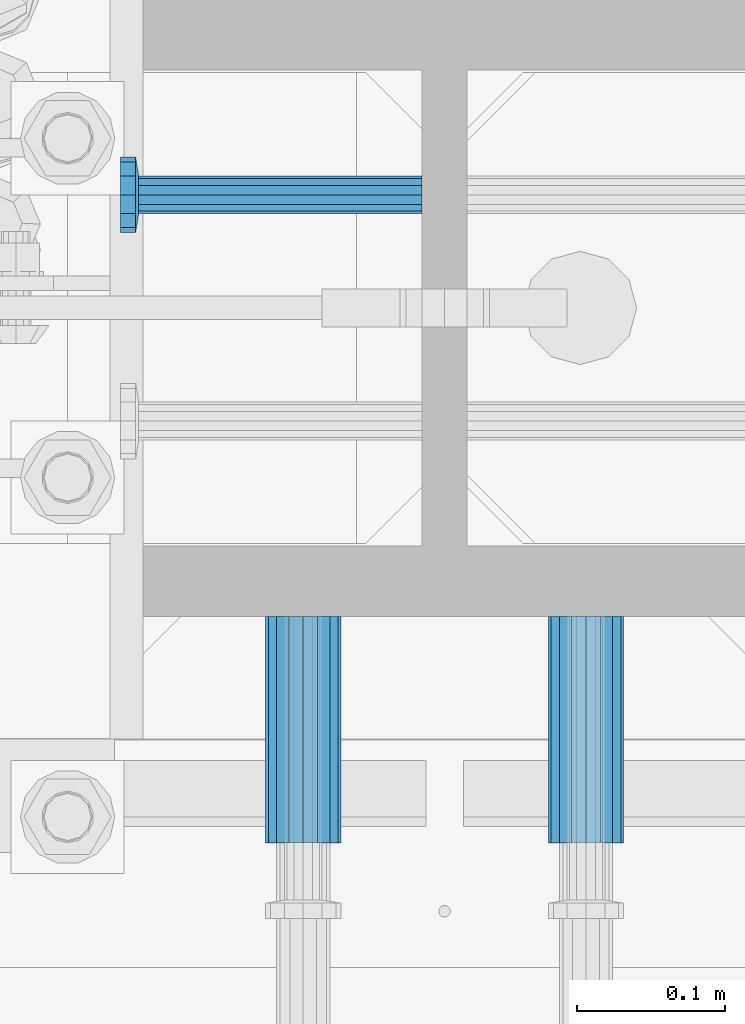
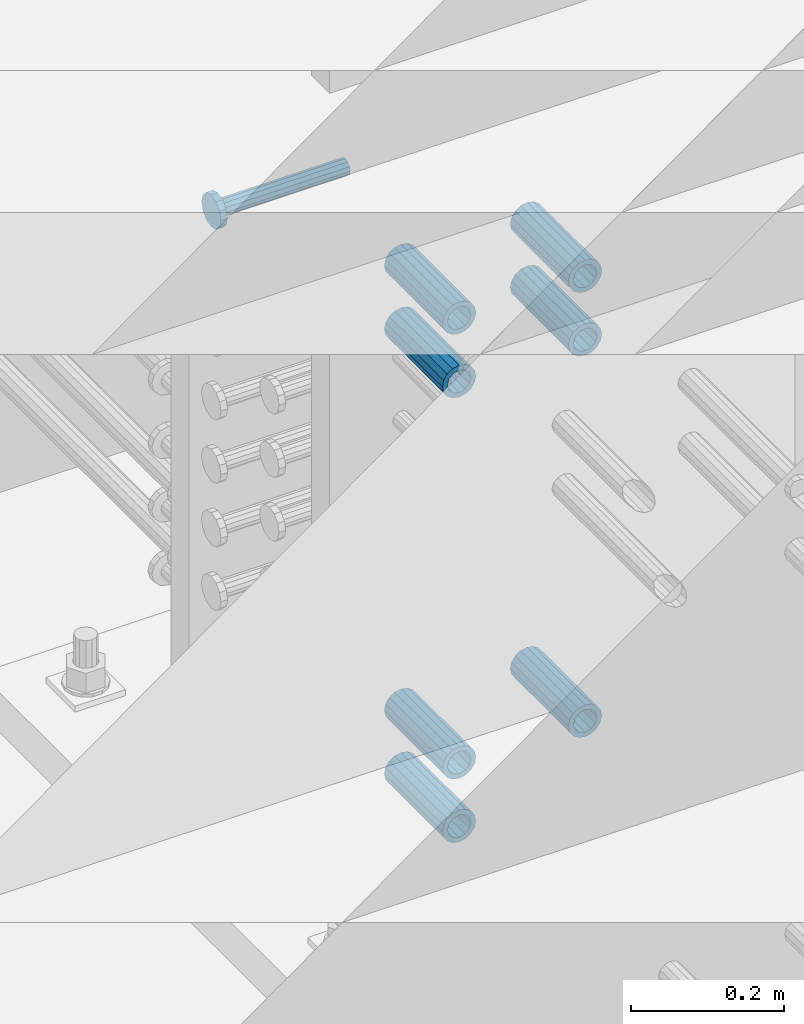
# One storey, part 1290 of 1763: 8 beams, 8 elements without a shape of their own.
"""IFC2X3 building model written with IfcOpenShell, lengths in millimetres."""

from ifc_helpers import new_model, si_unit, frame, origin_with_axes, place, context, subcontext, project, spatial, faceted_brep, material, type_object, element, aggregate, save


model = new_model("IFC2X3")

# Units and contexts
model_context = context("Model", 3, precision=1e-05, world=origin_with_axes())
body_context = subcontext(model_context, "Body", "Model", "MODEL_VIEW")
ifc_project = project(units=[si_unit("LENGTHUNIT", "METRE", prefix="MILLI"), si_unit("AREAUNIT", "SQUARE_METRE"), si_unit("VOLUMEUNIT", "CUBIC_METRE"), si_unit("MASSUNIT", "GRAM", prefix="KILO"), si_unit("TIMEUNIT", "SECOND"), si_unit("PLANEANGLEUNIT", "RADIAN"), si_unit("SOLIDANGLEUNIT", "STERADIAN"), si_unit("THERMODYNAMICTEMPERATUREUNIT", "DEGREE_CELSIUS"), si_unit("LUMINOUSINTENSITYUNIT", "LUMEN")], contexts=[model_context])

# Site, building, storey
site_placement = place(None, origin_with_axes())
site = spatial("IfcSite", under=ifc_project, at=site_placement, CompositionType="ELEMENT")
building_placement = place(site_placement, origin_with_axes())
building = spatial("IfcBuilding", under=site, at=building_placement, Name="Undefined", CompositionType="ELEMENT")
storey_placement = place(building_placement, origin_with_axes())
storey = spatial("IfcBuildingStorey", under=building, at=storey_placement, Name="Undefined", CompositionType="ELEMENT", Elevation=0.0)

# Assembly, beam
assembly_1_placement = place(storey_placement, origin_with_axes())
assembly_1 = element("IfcElementAssembly", 1, at=assembly_1_placement, inside=storey, Name="HALF COUPLER", AssemblyPlace="NOTDEFINED", PredefinedType="RIGID_FRAME")
ifc_material_1 = material(Name="STEEL/A706-GR.80")
beam_type_1 = type_object("IfcBeamType", PredefinedType="NOTDEFINED")
beam_1_placement = place(assembly_1_placement, frame((-23932.5872736985, -13923.9622483743, 4165.6), z_axis=(0.0, 0.0, 1.0), x_axis=(0.0, -1.0, 0.0)))
beam_1 = element("IfcBeam", 2, at=beam_1_placement, type_object=beam_type_1, material=ifc_material_1, Name="HALF COUPLER", context=body_context, shape_type="Brep", body=[
    faceted_brep([(32.7659999999996, -8.95349999999962, -15.507916905568), (32.7659999999996, 0.0, -17.9070000000002), (32.7659999999996, 8.95349999999962, -15.507916905568), (32.7659999999996, 15.507916905568, -8.95350000000008), (32.7659999999996, 17.9069999999992, 0.0), (32.7659999999996, 15.507916905568, 8.95350000000008), (32.7659999999996, 8.95349999999962, 15.507916905568), (32.7659999999996, 0.0, 17.9070000000002), (32.7659999999996, -8.95349999999962, 15.507916905568), (32.7659999999996, -15.507916905568, 8.95350000000008), (32.7659999999996, -17.9069999999992, 0.0), (32.7659999999996, -15.507916905568, -8.95350000000008), (152.400103102711, -15.507916905568, 8.95350000000008), (152.400103102711, -8.95349999999962, 15.507916905568), (152.400103102711, -17.9069999999992, 0.0), (152.400103102711, -15.507916905568, -8.95350000000008), (152.400103102711, -8.95349999999962, -15.507916905568), (152.400103102711, 0.0, -17.9070000000002), (152.400103102711, 8.95349999999962, -15.507916905568), (152.400103102711, 15.507916905568, -8.95350000000008), (152.400103102711, 17.9069999999992, 0.0), (152.400103102711, 15.507916905568, 8.95350000000008), (152.400103102711, 8.95349999999962, 15.507916905568), (152.400103102711, 0.0, 17.9070000000002), (0.0, -23.466540125788, 9.72015918207308), (0.0, -17.9605122421381, 17.9605122421385), (0.0, -9.72015918207398, 23.4665401257867), (0.0, 0.0, 25.4000000000001), (0.0, 9.72015918207398, 23.4665401257867), (0.0, 17.9605122421381, 17.9605122421385), (0.0, 23.466540125788, 9.72015918207308), (0.0, 25.4000000000015, 0.0), (0.0, 23.466540125788, -9.72015918207308), (0.0, 17.9605122421381, -17.9605122421385), (0.0, 9.72015918207398, -23.4665401257867), (0.0, 0.0, -25.4000000000001), (0.0, -9.72015918207398, -23.4665401257867), (0.0, -17.9605122421381, -17.9605122421385), (0.0, -23.466540125788, -9.72015918207308), (0.0, -25.4000000000015, 0.0), (152.400103102711, -25.4000000000015, 0.0), (152.400103102711, -23.466540125788, 9.72015918207308), (152.400103102711, -17.9605122421381, 17.9605122421385), (152.400103102711, -9.72015918207398, 23.4665401257867), (152.400103102711, 0.0, 25.4000000000001), (152.400103102711, 9.72015918207398, 23.4665401257867), (152.400103102711, 17.9605122421381, 17.9605122421385), (152.400103102711, 23.466540125788, 9.72015918207308), (152.400103102711, 25.4000000000015, 0.0), (152.400103102711, 23.466540125788, -9.72015918207308), (152.400103102711, 17.9605122421381, -17.9605122421385), (152.400103102711, 9.72015918207398, -23.4665401257867), (152.400103102711, 0.0, -25.4000000000001), (152.400103102711, -9.72015918207398, -23.4665401257867), (152.400103102711, -17.9605122421381, -17.9605122421385), (152.400103102711, -23.466540125788, -9.72015918207308)], [[[0, 1, 2, 3, 4, 5, 6, 7, 8, 9, 10, 11]], [[12, 9, 8, 13]], [[14, 10, 9, 12]], [[15, 11, 10, 14]], [[16, 0, 11, 15]], [[17, 1, 0, 16]], [[18, 2, 1, 17]], [[19, 3, 2, 18]], [[20, 4, 3, 19]], [[21, 5, 4, 20]], [[22, 6, 5, 21]], [[23, 7, 6, 22]], [[13, 8, 7, 23]], [[24, 25, 26, 27, 28, 29, 30, 31, 32, 33, 34, 35, 36, 37, 38, 39]], [[24, 39, 40, 41]], [[25, 24, 41, 42]], [[26, 25, 42, 43]], [[27, 26, 43, 44]], [[28, 27, 44, 45]], [[29, 28, 45, 46]], [[30, 29, 46, 47]], [[31, 30, 47, 48]], [[32, 31, 48, 49]], [[33, 32, 49, 50]], [[34, 33, 50, 51]], [[35, 34, 51, 52]], [[36, 35, 52, 53]], [[37, 36, 53, 54]], [[38, 37, 54, 55]], [[39, 38, 55, 40]], [[54, 53, 52, 51, 50, 49, 48, 47, 46, 45, 44, 43, 42, 41, 40, 55], [21, 20, 19, 18, 17, 16, 15, 14, 12, 13, 23, 22]]]),
])
aggregate(assembly_1, [beam_1])

assembly_2_placement = place(storey_placement, origin_with_axes())
assembly_2 = element("IfcElementAssembly", 3, at=assembly_2_placement, inside=storey, Name="HALF COUPLER", AssemblyPlace="NOTDEFINED", PredefinedType="RIGID_FRAME")
beam_2_placement = place(assembly_2_placement, frame((-24123.0872736984, -13923.9623171098, 4064.0), z_axis=(0.0, 0.0, 1.0), x_axis=(0.0, -1.0, 0.0)))
beam_2 = element("IfcBeam", 4, at=beam_2_placement, type_object=beam_type_1, material=ifc_material_1, Name="HALF COUPLER", context=body_context, shape_type="Brep", body=[
    faceted_brep([(32.7659999999996, -8.95349999999962, -15.507916905568), (32.7659999999996, 0.0, -17.9070000000002), (32.7659999999996, 8.95349999999962, -15.507916905568), (32.7659999999996, 15.507916905568, -8.95350000000008), (32.7659999999996, 17.9069999999992, 0.0), (32.7659999999996, 15.507916905568, 8.95350000000008), (32.7659999999996, 8.95349999999962, 15.507916905568), (32.7659999999996, 0.0, 17.9070000000002), (32.7659999999996, -8.95349999999962, 15.507916905568), (32.7659999999996, -15.507916905568, 8.95350000000008), (32.7659999999996, -17.9069999999992, 0.0), (32.7659999999996, -15.507916905568, -8.95350000000008), (152.400103102711, -15.507916905568, 8.95350000000008), (152.400103102711, -8.95349999999962, 15.507916905568), (152.400103102711, -17.9069999999992, 0.0), (152.400103102711, -15.507916905568, -8.95350000000008), (152.400103102711, -8.95349999999962, -15.507916905568), (152.400103102711, 0.0, -17.9070000000002), (152.400103102711, 8.95349999999962, -15.507916905568), (152.400103102711, 15.507916905568, -8.95350000000008), (152.400103102711, 17.9069999999992, 0.0), (152.400103102711, 15.507916905568, 8.95350000000008), (152.400103102711, 8.95349999999962, 15.507916905568), (152.400103102711, 0.0, 17.9070000000002), (0.0, -23.466540125788, 9.72015918207308), (0.0, -17.9605122421381, 17.9605122421385), (0.0, -9.72015918207398, 23.4665401257867), (0.0, 0.0, 25.4000000000001), (0.0, 9.72015918207398, 23.4665401257867), (0.0, 17.9605122421381, 17.9605122421385), (0.0, 23.466540125788, 9.72015918207308), (0.0, 25.4000000000015, 0.0), (0.0, 23.466540125788, -9.72015918207308), (0.0, 17.9605122421381, -17.9605122421385), (0.0, 9.72015918207398, -23.4665401257867), (0.0, 0.0, -25.4000000000001), (0.0, -9.72015918207398, -23.4665401257867), (0.0, -17.9605122421381, -17.9605122421385), (0.0, -23.466540125788, -9.72015918207308), (0.0, -25.4000000000015, 0.0), (152.400103102711, -25.4000000000015, 0.0), (152.400103102711, -23.466540125788, 9.72015918207308), (152.400103102711, -17.9605122421381, 17.9605122421385), (152.400103102711, -9.72015918207398, 23.4665401257867), (152.400103102711, 0.0, 25.4000000000001), (152.400103102711, 9.72015918207398, 23.4665401257867), (152.400103102711, 17.9605122421381, 17.9605122421385), (152.400103102711, 23.466540125788, 9.72015918207308), (152.400103102711, 25.4000000000015, 0.0), (152.400103102711, 23.466540125788, -9.72015918207308), (152.400103102711, 17.9605122421381, -17.9605122421385), (152.400103102711, 9.72015918207398, -23.4665401257867), (152.400103102711, 0.0, -25.4000000000001), (152.400103102711, -9.72015918207398, -23.4665401257867), (152.400103102711, -17.9605122421381, -17.9605122421385), (152.400103102711, -23.466540125788, -9.72015918207308)], [[[0, 1, 2, 3, 4, 5, 6, 7, 8, 9, 10, 11]], [[12, 9, 8, 13]], [[14, 10, 9, 12]], [[15, 11, 10, 14]], [[16, 0, 11, 15]], [[17, 1, 0, 16]], [[18, 2, 1, 17]], [[19, 3, 2, 18]], [[20, 4, 3, 19]], [[21, 5, 4, 20]], [[22, 6, 5, 21]], [[23, 7, 6, 22]], [[13, 8, 7, 23]], [[24, 25, 26, 27, 28, 29, 30, 31, 32, 33, 34, 35, 36, 37, 38, 39]], [[24, 39, 40, 41]], [[25, 24, 41, 42]], [[26, 25, 42, 43]], [[27, 26, 43, 44]], [[28, 27, 44, 45]], [[29, 28, 45, 46]], [[30, 29, 46, 47]], [[31, 30, 47, 48]], [[32, 31, 48, 49]], [[33, 32, 49, 50]], [[34, 33, 50, 51]], [[35, 34, 51, 52]], [[36, 35, 52, 53]], [[37, 36, 53, 54]], [[38, 37, 54, 55]], [[39, 38, 55, 40]], [[54, 53, 52, 51, 50, 49, 48, 47, 46, 45, 44, 43, 42, 41, 40, 55], [21, 20, 19, 18, 17, 16, 15, 14, 12, 13, 23, 22]]]),
])
aggregate(assembly_2, [beam_2])

assembly_3_placement = place(storey_placement, origin_with_axes())
assembly_3 = element("IfcElementAssembly", 5, at=assembly_3_placement, inside=storey, Name="HALF COUPLER", AssemblyPlace="NOTDEFINED", PredefinedType="RIGID_FRAME")
beam_3_placement = place(assembly_3_placement, frame((-24123.0872736984, -13923.9623171098, 4165.6), z_axis=(0.0, 0.0, 1.0), x_axis=(0.0, -1.0, 0.0)))
beam_3 = element("IfcBeam", 6, at=beam_3_placement, type_object=beam_type_1, material=ifc_material_1, Name="HALF COUPLER", context=body_context, shape_type="Brep", body=[
    faceted_brep([(32.7659999999996, -8.95349999999962, -15.507916905568), (32.7659999999996, 0.0, -17.9070000000002), (32.7659999999996, 8.95349999999962, -15.507916905568), (32.7659999999996, 15.507916905568, -8.95350000000008), (32.7659999999996, 17.9069999999992, 0.0), (32.7659999999996, 15.507916905568, 8.95350000000008), (32.7659999999996, 8.95349999999962, 15.507916905568), (32.7659999999996, 0.0, 17.9070000000002), (32.7659999999996, -8.95349999999962, 15.507916905568), (32.7659999999996, -15.507916905568, 8.95350000000008), (32.7659999999996, -17.9069999999992, 0.0), (32.7659999999996, -15.507916905568, -8.95350000000008), (152.400103102711, -15.507916905568, 8.95350000000008), (152.400103102711, -8.95349999999962, 15.507916905568), (152.400103102711, -17.9069999999992, 0.0), (152.400103102711, -15.507916905568, -8.95350000000008), (152.400103102711, -8.95349999999962, -15.507916905568), (152.400103102711, 0.0, -17.9070000000002), (152.400103102711, 8.95349999999962, -15.507916905568), (152.400103102711, 15.507916905568, -8.95350000000008), (152.400103102711, 17.9069999999992, 0.0), (152.400103102711, 15.507916905568, 8.95350000000008), (152.400103102711, 8.95349999999962, 15.507916905568), (152.400103102711, 0.0, 17.9070000000002), (0.0, -23.466540125788, 9.72015918207308), (0.0, -17.9605122421381, 17.9605122421385), (0.0, -9.72015918207398, 23.4665401257867), (0.0, 0.0, 25.4000000000001), (0.0, 9.72015918207398, 23.4665401257867), (0.0, 17.9605122421381, 17.9605122421385), (0.0, 23.466540125788, 9.72015918207308), (0.0, 25.4000000000015, 0.0), (0.0, 23.466540125788, -9.72015918207308), (0.0, 17.9605122421381, -17.9605122421385), (0.0, 9.72015918207398, -23.4665401257867), (0.0, 0.0, -25.4000000000001), (0.0, -9.72015918207398, -23.4665401257867), (0.0, -17.9605122421381, -17.9605122421385), (0.0, -23.466540125788, -9.72015918207308), (0.0, -25.4000000000015, 0.0), (152.400103102711, -25.4000000000015, 0.0), (152.400103102711, -23.466540125788, 9.72015918207308), (152.400103102711, -17.9605122421381, 17.9605122421385), (152.400103102711, -9.72015918207398, 23.4665401257867), (152.400103102711, 0.0, 25.4000000000001), (152.400103102711, 9.72015918207398, 23.4665401257867), (152.400103102711, 17.9605122421381, 17.9605122421385), (152.400103102711, 23.466540125788, 9.72015918207308), (152.400103102711, 25.4000000000015, 0.0), (152.400103102711, 23.466540125788, -9.72015918207308), (152.400103102711, 17.9605122421381, -17.9605122421385), (152.400103102711, 9.72015918207398, -23.4665401257867), (152.400103102711, 0.0, -25.4000000000001), (152.400103102711, -9.72015918207398, -23.4665401257867), (152.400103102711, -17.9605122421381, -17.9605122421385), (152.400103102711, -23.466540125788, -9.72015918207308)], [[[0, 1, 2, 3, 4, 5, 6, 7, 8, 9, 10, 11]], [[12, 9, 8, 13]], [[14, 10, 9, 12]], [[15, 11, 10, 14]], [[16, 0, 11, 15]], [[17, 1, 0, 16]], [[18, 2, 1, 17]], [[19, 3, 2, 18]], [[20, 4, 3, 19]], [[21, 5, 4, 20]], [[22, 6, 5, 21]], [[23, 7, 6, 22]], [[13, 8, 7, 23]], [[24, 25, 26, 27, 28, 29, 30, 31, 32, 33, 34, 35, 36, 37, 38, 39]], [[24, 39, 40, 41]], [[25, 24, 41, 42]], [[26, 25, 42, 43]], [[27, 26, 43, 44]], [[28, 27, 44, 45]], [[29, 28, 45, 46]], [[30, 29, 46, 47]], [[31, 30, 47, 48]], [[32, 31, 48, 49]], [[33, 32, 49, 50]], [[34, 33, 50, 51]], [[35, 34, 51, 52]], [[36, 35, 52, 53]], [[37, 36, 53, 54]], [[38, 37, 54, 55]], [[39, 38, 55, 40]], [[54, 53, 52, 51, 50, 49, 48, 47, 46, 45, 44, 43, 42, 41, 40, 55], [21, 20, 19, 18, 17, 16, 15, 14, 12, 13, 23, 22]]]),
])
aggregate(assembly_3, [beam_3])

assembly_4_placement = place(storey_placement, origin_with_axes())
assembly_4 = element("IfcElementAssembly", 7, at=assembly_4_placement, inside=storey, Name="HALF COUPLER", AssemblyPlace="NOTDEFINED", PredefinedType="RIGID_FRAME")
beam_4_placement = place(assembly_4_placement, frame((-24123.0872736984, -13923.9624545803, 4775.20000000009), z_axis=(0.0, 0.0, 1.0), x_axis=(0.0, -1.0, 0.0)))
beam_4 = element("IfcBeam", 8, at=beam_4_placement, type_object=beam_type_1, material=ifc_material_1, Name="HALF COUPLER", context=body_context, shape_type="Brep", body=[
    faceted_brep([(32.7659999999996, -8.95349999999962, -15.507916905568), (32.7659999999996, 0.0, -17.9070000000002), (32.7659999999996, 8.95349999999962, -15.507916905568), (32.7659999999996, 15.507916905568, -8.95350000000008), (32.7659999999996, 17.9069999999992, 0.0), (32.7659999999996, 15.507916905568, 8.95350000000008), (32.7659999999996, 8.95349999999962, 15.507916905568), (32.7659999999996, 0.0, 17.9070000000002), (32.7659999999996, -8.95349999999962, 15.507916905568), (32.7659999999996, -15.507916905568, 8.95350000000008), (32.7659999999996, -17.9069999999992, 0.0), (32.7659999999996, -15.507916905568, -8.95350000000008), (152.400103102711, -15.507916905568, 8.95350000000008), (152.400103102711, -8.95349999999962, 15.507916905568), (152.400103102711, -17.9069999999992, 0.0), (152.400103102711, -15.507916905568, -8.95350000000008), (152.400103102711, -8.95349999999962, -15.507916905568), (152.400103102711, 0.0, -17.9070000000002), (152.400103102711, 8.95349999999962, -15.507916905568), (152.400103102711, 15.507916905568, -8.95350000000008), (152.400103102711, 17.9069999999992, 0.0), (152.400103102711, 15.507916905568, 8.95350000000008), (152.400103102711, 8.95349999999962, 15.507916905568), (152.400103102711, 0.0, 17.9070000000002), (0.0, -23.466540125788, 9.72015918207308), (0.0, -17.9605122421381, 17.9605122421385), (0.0, -9.72015918207398, 23.4665401257867), (0.0, 0.0, 25.4000000000001), (0.0, 9.72015918207398, 23.4665401257867), (0.0, 17.9605122421381, 17.9605122421385), (0.0, 23.466540125788, 9.72015918207308), (0.0, 25.4000000000015, 0.0), (0.0, 23.466540125788, -9.72015918207308), (0.0, 17.9605122421381, -17.9605122421385), (0.0, 9.72015918207398, -23.4665401257867), (0.0, 0.0, -25.4000000000001), (0.0, -9.72015918207398, -23.4665401257867), (0.0, -17.9605122421381, -17.9605122421385), (0.0, -23.466540125788, -9.72015918207308), (0.0, -25.4000000000015, 0.0), (152.400103102711, -25.4000000000015, 0.0), (152.400103102711, -23.466540125788, 9.72015918207308), (152.400103102711, -17.9605122421381, 17.9605122421385), (152.400103102711, -9.72015918207398, 23.4665401257867), (152.400103102711, 0.0, 25.4000000000001), (152.400103102711, 9.72015918207398, 23.4665401257867), (152.400103102711, 17.9605122421381, 17.9605122421385), (152.400103102711, 23.466540125788, 9.72015918207308), (152.400103102711, 25.4000000000015, 0.0), (152.400103102711, 23.466540125788, -9.72015918207308), (152.400103102711, 17.9605122421381, -17.9605122421385), (152.400103102711, 9.72015918207398, -23.4665401257867), (152.400103102711, 0.0, -25.4000000000001), (152.400103102711, -9.72015918207398, -23.4665401257867), (152.400103102711, -17.9605122421381, -17.9605122421385), (152.400103102711, -23.466540125788, -9.72015918207308)], [[[0, 1, 2, 3, 4, 5, 6, 7, 8, 9, 10, 11]], [[12, 9, 8, 13]], [[14, 10, 9, 12]], [[15, 11, 10, 14]], [[16, 0, 11, 15]], [[17, 1, 0, 16]], [[18, 2, 1, 17]], [[19, 3, 2, 18]], [[20, 4, 3, 19]], [[21, 5, 4, 20]], [[22, 6, 5, 21]], [[23, 7, 6, 22]], [[13, 8, 7, 23]], [[24, 25, 26, 27, 28, 29, 30, 31, 32, 33, 34, 35, 36, 37, 38, 39]], [[24, 39, 40, 41]], [[25, 24, 41, 42]], [[26, 25, 42, 43]], [[27, 26, 43, 44]], [[28, 27, 44, 45]], [[29, 28, 45, 46]], [[30, 29, 46, 47]], [[31, 30, 47, 48]], [[32, 31, 48, 49]], [[33, 32, 49, 50]], [[34, 33, 50, 51]], [[35, 34, 51, 52]], [[36, 35, 52, 53]], [[37, 36, 53, 54]], [[38, 37, 54, 55]], [[39, 38, 55, 40]], [[54, 53, 52, 51, 50, 49, 48, 47, 46, 45, 44, 43, 42, 41, 40, 55], [21, 20, 19, 18, 17, 16, 15, 14, 12, 13, 23, 22]]]),
])
aggregate(assembly_4, [beam_4])

assembly_5_placement = place(storey_placement, origin_with_axes())
assembly_5 = element("IfcElementAssembly", 9, at=assembly_5_placement, inside=storey, Name="HALF COUPLER", AssemblyPlace="NOTDEFINED", PredefinedType="RIGID_FRAME")
beam_5_placement = place(assembly_5_placement, frame((-23932.5872736985, -13923.9623858448, 4775.20000000009), z_axis=(0.0, 0.0, 1.0), x_axis=(0.0, -1.0, 0.0)))
beam_5 = element("IfcBeam", 10, at=beam_5_placement, type_object=beam_type_1, material=ifc_material_1, Name="HALF COUPLER", context=body_context, shape_type="Brep", body=[
    faceted_brep([(32.7659999999996, -8.95349999999962, -15.507916905568), (32.7659999999996, 0.0, -17.9070000000002), (32.7659999999996, 8.95349999999962, -15.507916905568), (32.7659999999996, 15.507916905568, -8.95350000000008), (32.7659999999996, 17.9069999999992, 0.0), (32.7659999999996, 15.507916905568, 8.95350000000008), (32.7659999999996, 8.95349999999962, 15.507916905568), (32.7659999999996, 0.0, 17.9070000000002), (32.7659999999996, -8.95349999999962, 15.507916905568), (32.7659999999996, -15.507916905568, 8.95350000000008), (32.7659999999996, -17.9069999999992, 0.0), (32.7659999999996, -15.507916905568, -8.95350000000008), (152.400103102711, -15.507916905568, 8.95350000000008), (152.400103102711, -8.95349999999962, 15.507916905568), (152.400103102711, -17.9069999999992, 0.0), (152.400103102711, -15.507916905568, -8.95350000000008), (152.400103102711, -8.95349999999962, -15.507916905568), (152.400103102711, 0.0, -17.9070000000002), (152.400103102711, 8.95349999999962, -15.507916905568), (152.400103102711, 15.507916905568, -8.95350000000008), (152.400103102711, 17.9069999999992, 0.0), (152.400103102711, 15.507916905568, 8.95350000000008), (152.400103102711, 8.95349999999962, 15.507916905568), (152.400103102711, 0.0, 17.9070000000002), (0.0, -23.466540125788, 9.72015918207308), (0.0, -17.9605122421381, 17.9605122421385), (0.0, -9.72015918207398, 23.4665401257867), (0.0, 0.0, 25.4000000000001), (0.0, 9.72015918207398, 23.4665401257867), (0.0, 17.9605122421381, 17.9605122421385), (0.0, 23.466540125788, 9.72015918207308), (0.0, 25.4000000000015, 0.0), (0.0, 23.466540125788, -9.72015918207308), (0.0, 17.9605122421381, -17.9605122421385), (0.0, 9.72015918207398, -23.4665401257867), (0.0, 0.0, -25.4000000000001), (0.0, -9.72015918207398, -23.4665401257867), (0.0, -17.9605122421381, -17.9605122421385), (0.0, -23.466540125788, -9.72015918207308), (0.0, -25.4000000000015, 0.0), (152.400103102711, -25.4000000000015, 0.0), (152.400103102711, -23.466540125788, 9.72015918207308), (152.400103102711, -17.9605122421381, 17.9605122421385), (152.400103102711, -9.72015918207398, 23.4665401257867), (152.400103102711, 0.0, 25.4000000000001), (152.400103102711, 9.72015918207398, 23.4665401257867), (152.400103102711, 17.9605122421381, 17.9605122421385), (152.400103102711, 23.466540125788, 9.72015918207308), (152.400103102711, 25.4000000000015, 0.0), (152.400103102711, 23.466540125788, -9.72015918207308), (152.400103102711, 17.9605122421381, -17.9605122421385), (152.400103102711, 9.72015918207398, -23.4665401257867), (152.400103102711, 0.0, -25.4000000000001), (152.400103102711, -9.72015918207398, -23.4665401257867), (152.400103102711, -17.9605122421381, -17.9605122421385), (152.400103102711, -23.466540125788, -9.72015918207308)], [[[0, 1, 2, 3, 4, 5, 6, 7, 8, 9, 10, 11]], [[12, 9, 8, 13]], [[14, 10, 9, 12]], [[15, 11, 10, 14]], [[16, 0, 11, 15]], [[17, 1, 0, 16]], [[18, 2, 1, 17]], [[19, 3, 2, 18]], [[20, 4, 3, 19]], [[21, 5, 4, 20]], [[22, 6, 5, 21]], [[23, 7, 6, 22]], [[13, 8, 7, 23]], [[24, 25, 26, 27, 28, 29, 30, 31, 32, 33, 34, 35, 36, 37, 38, 39]], [[24, 39, 40, 41]], [[25, 24, 41, 42]], [[26, 25, 42, 43]], [[27, 26, 43, 44]], [[28, 27, 44, 45]], [[29, 28, 45, 46]], [[30, 29, 46, 47]], [[31, 30, 47, 48]], [[32, 31, 48, 49]], [[33, 32, 49, 50]], [[34, 33, 50, 51]], [[35, 34, 51, 52]], [[36, 35, 52, 53]], [[37, 36, 53, 54]], [[38, 37, 54, 55]], [[39, 38, 55, 40]], [[54, 53, 52, 51, 50, 49, 48, 47, 46, 45, 44, 43, 42, 41, 40, 55], [21, 20, 19, 18, 17, 16, 15, 14, 12, 13, 23, 22]]]),
])
aggregate(assembly_5, [beam_5])

assembly_6_placement = place(storey_placement, origin_with_axes())
assembly_6 = element("IfcElementAssembly", 11, at=assembly_6_placement, inside=storey, Name="HALF COUPLER", AssemblyPlace="NOTDEFINED", PredefinedType="RIGID_FRAME")
beam_6_placement = place(assembly_6_placement, frame((-24123.0872736984, -13923.9625920513, 4876.80000000009), z_axis=(0.0, 0.0, 1.0), x_axis=(0.0, -1.0, 0.0)))
beam_6 = element("IfcBeam", 12, at=beam_6_placement, type_object=beam_type_1, material=ifc_material_1, Name="HALF COUPLER", context=body_context, shape_type="Brep", body=[
    faceted_brep([(32.7659999999996, -8.95349999999962, -15.507916905568), (32.7659999999996, 0.0, -17.9070000000002), (32.7659999999996, 8.95349999999962, -15.507916905568), (32.7659999999996, 15.507916905568, -8.95350000000008), (32.7659999999996, 17.9069999999992, 0.0), (32.7659999999996, 15.507916905568, 8.95350000000008), (32.7659999999996, 8.95349999999962, 15.507916905568), (32.7659999999996, 0.0, 17.9070000000002), (32.7659999999996, -8.95349999999962, 15.507916905568), (32.7659999999996, -15.507916905568, 8.95350000000008), (32.7659999999996, -17.9069999999992, 0.0), (32.7659999999996, -15.507916905568, -8.95350000000008), (152.400103102711, -15.507916905568, 8.95350000000008), (152.400103102711, -8.95349999999962, 15.507916905568), (152.400103102711, -17.9069999999992, 0.0), (152.400103102711, -15.507916905568, -8.95350000000008), (152.400103102711, -8.95349999999962, -15.507916905568), (152.400103102711, 0.0, -17.9070000000002), (152.400103102711, 8.95349999999962, -15.507916905568), (152.400103102711, 15.507916905568, -8.95350000000008), (152.400103102711, 17.9069999999992, 0.0), (152.400103102711, 15.507916905568, 8.95350000000008), (152.400103102711, 8.95349999999962, 15.507916905568), (152.400103102711, 0.0, 17.9070000000002), (0.0, -23.466540125788, 9.72015918207308), (0.0, -17.9605122421381, 17.9605122421385), (0.0, -9.72015918207398, 23.4665401257867), (0.0, 0.0, 25.4000000000001), (0.0, 9.72015918207398, 23.4665401257867), (0.0, 17.9605122421381, 17.9605122421385), (0.0, 23.466540125788, 9.72015918207308), (0.0, 25.4000000000015, 0.0), (0.0, 23.466540125788, -9.72015918207308), (0.0, 17.9605122421381, -17.9605122421385), (0.0, 9.72015918207398, -23.4665401257867), (0.0, 0.0, -25.4000000000001), (0.0, -9.72015918207398, -23.4665401257867), (0.0, -17.9605122421381, -17.9605122421385), (0.0, -23.466540125788, -9.72015918207308), (0.0, -25.4000000000015, 0.0), (152.400103102711, -25.4000000000015, 0.0), (152.400103102711, -23.466540125788, 9.72015918207308), (152.400103102711, -17.9605122421381, 17.9605122421385), (152.400103102711, -9.72015918207398, 23.4665401257867), (152.400103102711, 0.0, 25.4000000000001), (152.400103102711, 9.72015918207398, 23.4665401257867), (152.400103102711, 17.9605122421381, 17.9605122421385), (152.400103102711, 23.466540125788, 9.72015918207308), (152.400103102711, 25.4000000000015, 0.0), (152.400103102711, 23.466540125788, -9.72015918207308), (152.400103102711, 17.9605122421381, -17.9605122421385), (152.400103102711, 9.72015918207398, -23.4665401257867), (152.400103102711, 0.0, -25.4000000000001), (152.400103102711, -9.72015918207398, -23.4665401257867), (152.400103102711, -17.9605122421381, -17.9605122421385), (152.400103102711, -23.466540125788, -9.72015918207308)], [[[0, 1, 2, 3, 4, 5, 6, 7, 8, 9, 10, 11]], [[12, 9, 8, 13]], [[14, 10, 9, 12]], [[15, 11, 10, 14]], [[16, 0, 11, 15]], [[17, 1, 0, 16]], [[18, 2, 1, 17]], [[19, 3, 2, 18]], [[20, 4, 3, 19]], [[21, 5, 4, 20]], [[22, 6, 5, 21]], [[23, 7, 6, 22]], [[13, 8, 7, 23]], [[24, 25, 26, 27, 28, 29, 30, 31, 32, 33, 34, 35, 36, 37, 38, 39]], [[24, 39, 40, 41]], [[25, 24, 41, 42]], [[26, 25, 42, 43]], [[27, 26, 43, 44]], [[28, 27, 44, 45]], [[29, 28, 45, 46]], [[30, 29, 46, 47]], [[31, 30, 47, 48]], [[32, 31, 48, 49]], [[33, 32, 49, 50]], [[34, 33, 50, 51]], [[35, 34, 51, 52]], [[36, 35, 52, 53]], [[37, 36, 53, 54]], [[38, 37, 54, 55]], [[39, 38, 55, 40]], [[54, 53, 52, 51, 50, 49, 48, 47, 46, 45, 44, 43, 42, 41, 40, 55], [21, 20, 19, 18, 17, 16, 15, 14, 12, 13, 23, 22]]]),
])
aggregate(assembly_6, [beam_6])

assembly_7_placement = place(storey_placement, origin_with_axes())
assembly_7 = element("IfcElementAssembly", 13, at=assembly_7_placement, inside=storey, Name="HALF COUPLER", AssemblyPlace="NOTDEFINED", PredefinedType="RIGID_FRAME")
beam_7_placement = place(assembly_7_placement, frame((-23932.5872736985, -13923.9625233158, 4876.80000000009), z_axis=(0.0, 0.0, 1.0), x_axis=(0.0, -1.0, 0.0)))
beam_7 = element("IfcBeam", 14, at=beam_7_placement, type_object=beam_type_1, material=ifc_material_1, Name="HALF COUPLER", context=body_context, shape_type="Brep", body=[
    faceted_brep([(32.7659999999996, -8.95349999999962, -15.507916905568), (32.7659999999996, 0.0, -17.9070000000002), (32.7659999999996, 8.95349999999962, -15.507916905568), (32.7659999999996, 15.507916905568, -8.95350000000008), (32.7659999999996, 17.9069999999992, 0.0), (32.7659999999996, 15.507916905568, 8.95350000000008), (32.7659999999996, 8.95349999999962, 15.507916905568), (32.7659999999996, 0.0, 17.9070000000002), (32.7659999999996, -8.95349999999962, 15.507916905568), (32.7659999999996, -15.507916905568, 8.95350000000008), (32.7659999999996, -17.9069999999992, 0.0), (32.7659999999996, -15.507916905568, -8.95350000000008), (152.400103102711, -15.507916905568, 8.95350000000008), (152.400103102711, -8.95349999999962, 15.507916905568), (152.400103102711, -17.9069999999992, 0.0), (152.400103102711, -15.507916905568, -8.95350000000008), (152.400103102711, -8.95349999999962, -15.507916905568), (152.400103102711, 0.0, -17.9070000000002), (152.400103102711, 8.95349999999962, -15.507916905568), (152.400103102711, 15.507916905568, -8.95350000000008), (152.400103102711, 17.9069999999992, 0.0), (152.400103102711, 15.507916905568, 8.95350000000008), (152.400103102711, 8.95349999999962, 15.507916905568), (152.400103102711, 0.0, 17.9070000000002), (0.0, -23.466540125788, 9.72015918207308), (0.0, -17.9605122421381, 17.9605122421385), (0.0, -9.72015918207398, 23.4665401257867), (0.0, 0.0, 25.4000000000001), (0.0, 9.72015918207398, 23.4665401257867), (0.0, 17.9605122421381, 17.9605122421385), (0.0, 23.466540125788, 9.72015918207308), (0.0, 25.4000000000015, 0.0), (0.0, 23.466540125788, -9.72015918207308), (0.0, 17.9605122421381, -17.9605122421385), (0.0, 9.72015918207398, -23.4665401257867), (0.0, 0.0, -25.4000000000001), (0.0, -9.72015918207398, -23.4665401257867), (0.0, -17.9605122421381, -17.9605122421385), (0.0, -23.466540125788, -9.72015918207308), (0.0, -25.4000000000015, 0.0), (152.400103102711, -25.4000000000015, 0.0), (152.400103102711, -23.466540125788, 9.72015918207308), (152.400103102711, -17.9605122421381, 17.9605122421385), (152.400103102711, -9.72015918207398, 23.4665401257867), (152.400103102711, 0.0, 25.4000000000001), (152.400103102711, 9.72015918207398, 23.4665401257867), (152.400103102711, 17.9605122421381, 17.9605122421385), (152.400103102711, 23.466540125788, 9.72015918207308), (152.400103102711, 25.4000000000015, 0.0), (152.400103102711, 23.466540125788, -9.72015918207308), (152.400103102711, 17.9605122421381, -17.9605122421385), (152.400103102711, 9.72015918207398, -23.4665401257867), (152.400103102711, 0.0, -25.4000000000001), (152.400103102711, -9.72015918207398, -23.4665401257867), (152.400103102711, -17.9605122421381, -17.9605122421385), (152.400103102711, -23.466540125788, -9.72015918207308)], [[[0, 1, 2, 3, 4, 5, 6, 7, 8, 9, 10, 11]], [[12, 9, 8, 13]], [[14, 10, 9, 12]], [[15, 11, 10, 14]], [[16, 0, 11, 15]], [[17, 1, 0, 16]], [[18, 2, 1, 17]], [[19, 3, 2, 18]], [[20, 4, 3, 19]], [[21, 5, 4, 20]], [[22, 6, 5, 21]], [[23, 7, 6, 22]], [[13, 8, 7, 23]], [[24, 25, 26, 27, 28, 29, 30, 31, 32, 33, 34, 35, 36, 37, 38, 39]], [[24, 39, 40, 41]], [[25, 24, 41, 42]], [[26, 25, 42, 43]], [[27, 26, 43, 44]], [[28, 27, 44, 45]], [[29, 28, 45, 46]], [[30, 29, 46, 47]], [[31, 30, 47, 48]], [[32, 31, 48, 49]], [[33, 32, 49, 50]], [[34, 33, 50, 51]], [[35, 34, 51, 52]], [[36, 35, 52, 53]], [[37, 36, 53, 54]], [[38, 37, 54, 55]], [[39, 38, 55, 40]], [[54, 53, 52, 51, 50, 49, 48, 47, 46, 45, 44, 43, 42, 41, 40, 55], [21, 20, 19, 18, 17, 16, 15, 14, 12, 13, 23, 22]]]),
])
aggregate(assembly_7, [beam_7])

assembly_8_placement = place(storey_placement, origin_with_axes())
assembly_8 = element("IfcElementAssembly", 15, at=assembly_8_placement, inside=storey, Name="COLUMN", AssemblyPlace="NOTDEFINED", PredefinedType="RIGID_FRAME")
ifc_material_2 = material(Name="STEEL/A108")
beam_type_2 = type_object("IfcBeamType", PredefinedType="NOTDEFINED")
beam_8_placement = place(assembly_8_placement, frame((-24042.9185299162, -13639.7999316071, 4826.00000000008), z_axis=(0.0, -1.0, 0.0), x_axis=(-1.0, 0.0, 0.0)))
beam_8 = element("IfcBeam", 16, at=beam_8_placement, type_object=beam_type_2, material=ifc_material_2, Name="HEADED STUD ANCHOR", context=body_context, shape_type="Brep", body=[
    faceted_brep([(0.0, -12.6999999999971, -1.81898940354586e-12), (3.63797880709171e-12, -11.0, -6.34999990463257), (191.00799999576, -11.0, -6.34999990454889), (191.007999995752, -12.6999998092651, 8.36735125631094e-11), (7.27595761418343e-12, -6.34999990463257, -11.0), (191.00799999576, -6.34999990463257, -10.9999999999163), (3.63797880709171e-12, 0.0, -12.6999998092651), (191.00799999576, 0.0, -12.6999998091815), (7.27595761418343e-12, 6.34999990463257, -11.0), (191.00799999576, 6.34999990463257, -10.9999999999163), (3.63797880709171e-12, 11.0, -6.34999990463257), (191.00799999576, 11.0, -6.34999990454889), (0.0, 12.6999999999971, -1.81898940354586e-12), (191.007999995752, 12.6999998092651, 8.36735125631094e-11), (0.0, 11.0, 6.34999990463257), (191.007999995752, 11.0, 6.34999990471624), (-3.63797880709171e-12, 6.34999990463257, 11.0), (191.007999995749, 6.34999990463257, 11.0000000000837), (-3.63797880709171e-12, 0.0, 12.6999998092651), (191.007999995749, 0.0, 12.6999998093488), (-3.63797880709171e-12, -6.34999990463257, 11.0), (191.007999995749, -6.34999990463257, 11.0000000000837), (0.0, -11.0, 6.34999990463257), (191.007999995752, -11.0, 6.34999990471624), (193.039999995715, -22.0, -12.6999998091796), (193.039999995708, -25.3999996185303, 8.54925019666553e-11), (193.039999995719, -12.6999998092651, -21.9999999999145), (193.039999995719, 0.0, -25.3999996184448), (193.039999995719, 12.6999998092651, -21.9999999999145), (193.039999995715, 22.0, -12.6999998091796), (193.039999995708, 25.3999996185303, 8.54925019666553e-11), (193.039999995704, 22.0, 12.6999998093506), (193.039999995701, 12.6999998092651, 22.0000000000855), (193.039999995697, 0.0, 25.3999996186158), (193.039999995701, -12.6999998092651, 22.0000000000855), (193.039999995704, -22.0, 12.6999998093506), (203.199999995486, -22.0, -12.6999998091742), (203.199999995482, -25.3999996185303, 9.09494701772928e-11), (203.199999995493, -12.6999998092651, -21.9999999999091), (203.199999995493, 0.0, -25.3999996184393), (203.199999995493, 12.6999998092651, -21.9999999999091), (203.199999995486, 22.0, -12.6999998091742), (203.199999995482, 25.3999996185303, 9.09494701772928e-11), (203.199999995479, 22.0, 12.6999998093561), (203.199999995475, 12.6999998092651, 22.0000000000909), (203.199999995471, 0.0, 25.3999996186212), (203.199999995475, -12.6999998092651, 22.0000000000909), (203.199999995479, -22.0, 12.6999998093561)], [[[0, 1, 2, 3]], [[1, 4, 5, 2]], [[4, 6, 7, 5]], [[6, 8, 9, 7]], [[8, 10, 11, 9]], [[10, 12, 13, 11]], [[12, 14, 15, 13]], [[14, 16, 17, 15]], [[16, 18, 19, 17]], [[18, 20, 21, 19]], [[20, 22, 23, 21]], [[22, 0, 3, 23]], [[22, 20, 18, 16, 14, 12, 10, 8, 6, 4, 1, 0]], [[3, 2, 24, 25]], [[2, 5, 26, 24]], [[5, 7, 27, 26]], [[7, 9, 28, 27]], [[9, 11, 29, 28]], [[11, 13, 30, 29]], [[13, 15, 31, 30]], [[15, 17, 32, 31]], [[17, 19, 33, 32]], [[19, 21, 34, 33]], [[21, 23, 35, 34]], [[23, 3, 25, 35]], [[25, 24, 36, 37]], [[24, 26, 38, 36]], [[26, 27, 39, 38]], [[27, 28, 40, 39]], [[28, 29, 41, 40]], [[29, 30, 42, 41]], [[30, 31, 43, 42]], [[31, 32, 44, 43]], [[32, 33, 45, 44]], [[33, 34, 46, 45]], [[34, 35, 47, 46]], [[35, 25, 37, 47]], [[38, 39, 40, 41, 42, 43, 44, 45, 46, 47, 37, 36]]]),
])
aggregate(assembly_8, [beam_8])

save(model, "model.ifc")
